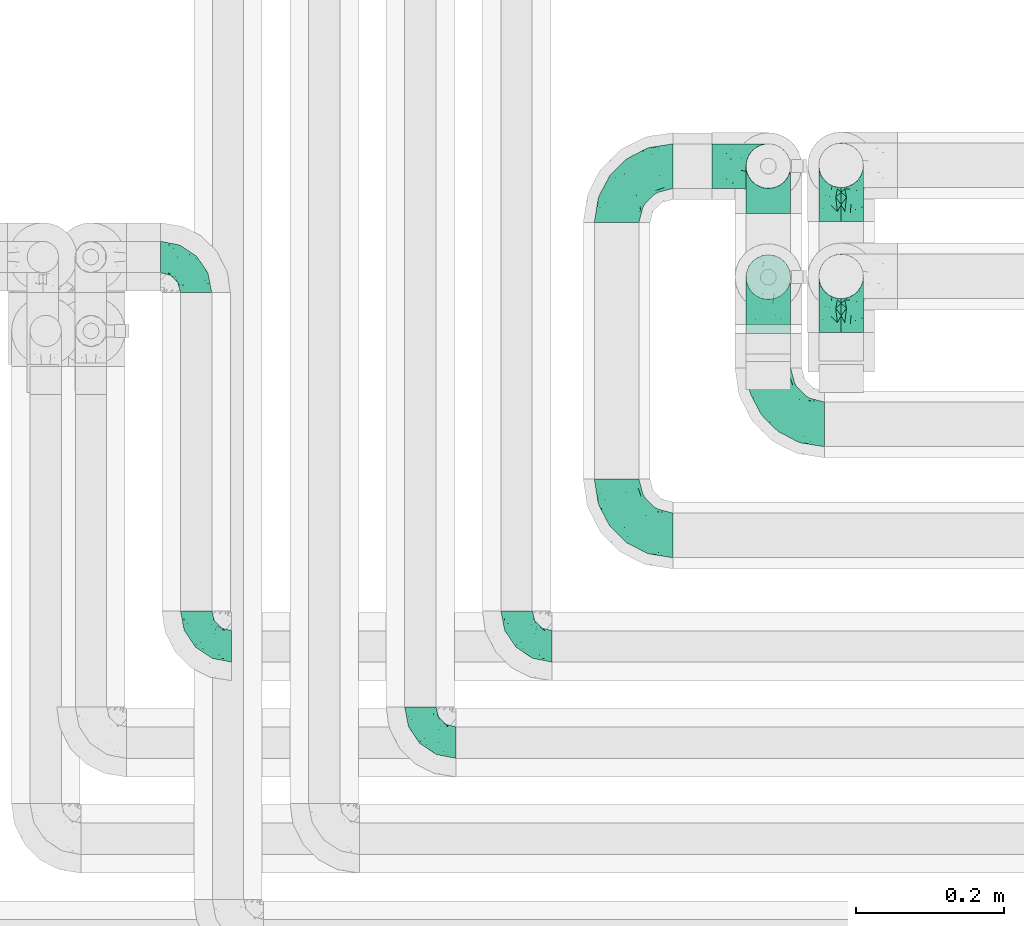
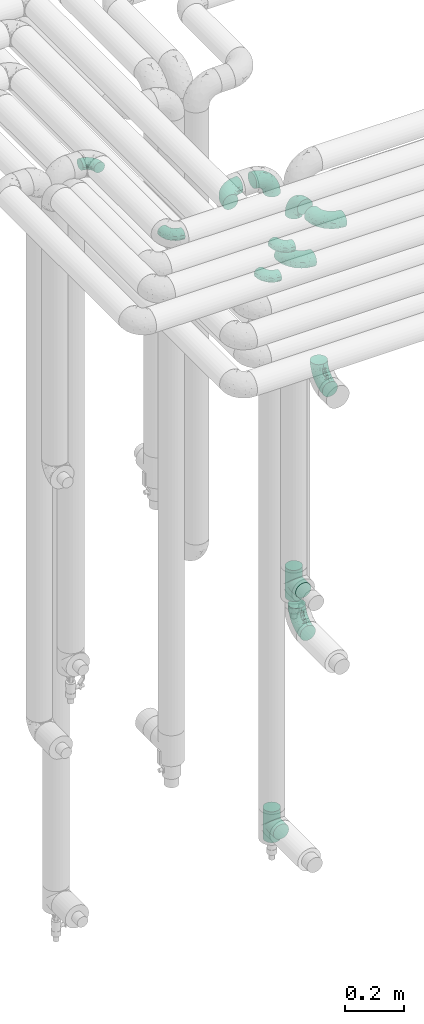
# One storey, part 631 of 827: 13 flow fittings.
"""IFC2X3 building model written with IfcOpenShell, lengths in millimetres."""

from ifc_helpers import new_model, entity, si_unit, converted_unit, derived_unit, direction, frame, origin, place, context, subcontext, project, spatial, faceted_brep, source, transform, mapped, material, type_object, type_shapes, element, save


model = new_model("IFC2X3")

# Units and contexts
model_context = context("Model", 3, precision=0.01, world=origin(), true_north=direction((6.12303176911189e-17, 1.0)))
body_context = subcontext(model_context, "Body", "Model", "MODEL_VIEW")
ifc_project = project(units=[si_unit("LENGTHUNIT", "METRE", prefix="MILLI"), si_unit("AREAUNIT", "SQUARE_METRE"), si_unit("VOLUMEUNIT", "CUBIC_METRE"), converted_unit("PLANEANGLEUNIT", "DEGREE", entity("IfcRatioMeasure", 0.0174532925199433), si_unit("PLANEANGLEUNIT", "RADIAN"), dimensions=[0, 0, 0, 0, 0, 0, 0]), si_unit("MASSUNIT", "GRAM", prefix="KILO"), derived_unit("MASSDENSITYUNIT", [(si_unit("MASSUNIT", "GRAM", prefix="KILO"), 1), (si_unit("LENGTHUNIT", "METRE"), -3)]), derived_unit("MOMENTOFINERTIAUNIT", [(si_unit("LENGTHUNIT", "METRE"), 4)]), si_unit("TIMEUNIT", "SECOND"), si_unit("FREQUENCYUNIT", "HERTZ"), si_unit("THERMODYNAMICTEMPERATUREUNIT", "DEGREE_CELSIUS"), derived_unit("THERMALTRANSMITTANCEUNIT", [(si_unit("MASSUNIT", "GRAM", prefix="KILO"), 1), (si_unit("THERMODYNAMICTEMPERATUREUNIT", "KELVIN"), -1), (si_unit("TIMEUNIT", "SECOND"), -3)]), derived_unit("VOLUMETRICFLOWRATEUNIT", [(si_unit("LENGTHUNIT", "METRE"), 3), (si_unit("TIMEUNIT", "SECOND"), -1)]), derived_unit("MASSFLOWRATEUNIT", [(si_unit("MASSUNIT", "GRAM", prefix="KILO"), 1), (si_unit("TIMEUNIT", "SECOND"), -1)]), derived_unit("ROTATIONALFREQUENCYUNIT", [(si_unit("TIMEUNIT", "SECOND"), -1)]), si_unit("ELECTRICCURRENTUNIT", "AMPERE"), si_unit("ELECTRICVOLTAGEUNIT", "VOLT"), si_unit("POWERUNIT", "WATT"), si_unit("FORCEUNIT", "NEWTON", prefix="KILO"), si_unit("ILLUMINANCEUNIT", "LUX"), si_unit("LUMINOUSFLUXUNIT", "LUMEN"), si_unit("LUMINOUSINTENSITYUNIT", "CANDELA"), derived_unit("USERDEFINED", [(si_unit("MASSUNIT", "GRAM", prefix="KILO"), -1), (si_unit("LENGTHUNIT", "METRE"), -2), (si_unit("TIMEUNIT", "SECOND"), 3), (si_unit("LUMINOUSFLUXUNIT", "LUMEN"), 1)]), derived_unit("LINEARVELOCITYUNIT", [(si_unit("LENGTHUNIT", "METRE"), 1), (si_unit("TIMEUNIT", "SECOND"), -1)]), si_unit("PRESSUREUNIT", "PASCAL"), derived_unit("USERDEFINED", [(si_unit("LENGTHUNIT", "METRE"), -2), (si_unit("MASSUNIT", "GRAM", prefix="KILO"), 1), (si_unit("TIMEUNIT", "SECOND"), -2)]), derived_unit("LINEARFORCEUNIT", [(si_unit("MASSUNIT", "GRAM", prefix="KILO"), 1), (si_unit("LENGTHUNIT", "METRE"), 1), (si_unit("TIMEUNIT", "SECOND"), -2), (si_unit("LENGTHUNIT", "METRE"), -1)]), derived_unit("PLANARFORCEUNIT", [(si_unit("MASSUNIT", "GRAM", prefix="KILO"), 1), (si_unit("LENGTHUNIT", "METRE"), 1), (si_unit("TIMEUNIT", "SECOND"), -2), (si_unit("LENGTHUNIT", "METRE"), -2)])], contexts=[model_context])

# Site, building, storey
site_placement = place(None, origin())
site = spatial("IfcSite", under=ifc_project, at=site_placement, CompositionType="ELEMENT")
building_placement = place(site_placement, origin())
building = spatial("IfcBuilding", under=site, at=building_placement, CompositionType="ELEMENT")
storey_placement = place(building_placement, frame((0.0, 0.0, 28200.0)))
storey = spatial("IfcBuildingStorey", under=building, at=storey_placement, Name="08", CompositionType="ELEMENT", Elevation=28200.0)

# Flow fittings
ifc_material = material()
pipe_fitting_type_1 = type_object("IfcPipeFittingType", Name="ADSK_1", PredefinedType="NOTDEFINED", material=ifc_material)
shared_shape_1 = source(origin(), body_context, "Body", "Brep", [
    faceted_brep([(-48.0, 10.6, -18.36), (-48.0, 5.49, -20.48), (-48.0, 0.0, -21.2), (-48.0, -5.49, -20.48), (-48.0, -10.6, -18.36), (-48.0, -14.99, -14.99), (-48.0, -18.36, -10.6), (-48.0, -20.48, -5.49), (-48.0, -21.2, 0.0), (-48.0, -20.48, 5.49), (-48.0, -18.36, 10.6), (-48.0, -14.99, 14.99), (-48.0, -10.6, 18.36), (-48.0, -5.49, 20.48), (-48.0, 0.0, 21.2), (-48.0, 5.49, 20.48), (-48.0, 10.6, 18.36), (-48.0, 14.99, 14.99), (-48.0, 18.36, 10.6), (-48.0, 20.48, 5.49), (-48.0, 21.2, 0.0), (-48.0, 20.48, -5.49), (-48.0, 18.36, -10.6), (-48.0, 14.99, -14.99), (0.0, 48.0, -21.2), (-5.49, 48.0, -20.48), (-10.6, 48.0, -18.36), (-14.99, 48.0, -14.99), (-18.36, 48.0, -10.6), (-20.48, 48.0, -5.49), (-21.2, 48.0, 0.0), (-20.48, 48.0, 5.49), (-18.36, 48.0, 10.6), (-14.99, 48.0, 14.99), (-10.6, 48.0, 18.36), (-5.49, 48.0, 20.48), (0.0, 48.0, 21.2), (5.49, 48.0, 20.48), (10.6, 48.0, 18.36), (14.99, 48.0, 14.99), (18.36, 48.0, 10.6), (20.48, 48.0, 5.49), (21.2, 48.0, 0.0), (20.48, 48.0, -5.49), (18.36, 48.0, -10.6), (14.99, 48.0, -14.99), (10.6, 48.0, -18.36), (5.49, 48.0, -20.48), (-35.25, -16.22, 12.01), (-34.76, -18.57, 0.0), (-20.87, -12.37, 10.9), (-31.49, -11.78, 15.9), (-37.0, -2.58, 20.86), (-33.89, 3.62, 21.15), (-31.81, -18.14, 6.76), (-5.78, 5.78, 17.67), (-19.42, -4.1, 17.86), (-9.6, -3.39, 13.73), (-35.44, -7.73, 19.13), (11.78, 31.49, 15.9), (-5.93, -5.46, 6.95), (-18.45, -13.78, 5.46), (-10.29, -8.43, 0.0), (-24.6, 0.55, 20.62), (-37.28, 17.94, 13.81), (-33.38, 22.85, 9.59), (-41.46, 20.06, 8.75), (-29.51, 20.45, 15.16), (-15.04, 10.79, 21.13), (-7.08, 16.98, 20.93), (-8.39, 23.51, 21.15), (-40.86, 13.03, 17.26), (-8.05, 41.26, 19.83), (-3.21, 35.97, 21.14), (8.53, 19.66, 14.74), (4.1, 19.42, 17.86), (-37.72, 22.66, 4.78), (-37.07, 8.58, 19.98), (-13.0, 5.43, 19.97), (-3.78, 13.93, 19.7), (3.02, 8.69, 13.43), (-2.27, -0.05, 10.65), (6.22, 6.99, 7.09), (-22.25, 34.6, 9.45), (18.14, 31.81, 6.76), (16.22, 35.25, 12.01), (12.37, 20.87, 10.9), (7.73, 35.44, 19.13), (-21.52, -15.93, 0.0), (2.58, 37.0, 20.86), (18.57, 34.76, 0.0), (13.78, 18.45, 5.46), (15.93, 21.52, 0.0), (-20.03, -8.54, 14.9), (-28.6, 28.6, 5.16), (-24.79, 34.6, 0.0), (-34.6, 24.79, 0.0), (-22.81, 37.41, 4.68), (-23.36, 26.33, 14.79), (-13.68, 37.05, 17.49), (-17.72, 38.12, 13.73), (-26.25, 27.3, 11.24), (-9.71, 32.34, 20.14), (-17.26, 25.6, 18.71), (-26.33, 9.99, 20.77), (-24.06, 6.05, 21.2), (-25.02, 15.46, 19.56), (-24.3, 20.72, 17.57), (-31.95, 15.23, 17.8), (-13.53, 24.7, 20.21), (-17.6, 17.6, 20.6), (-0.55, 24.6, 20.62), (-11.41, -7.48, 10.43), (0.93, -0.93, 0.0), (8.43, 10.29, 0.0), (-11.41, -7.48, -10.43), (-20.1, -8.84, -14.66), (-9.6, -3.39, -13.73), (7.73, 35.44, -19.13), (4.1, 19.42, -17.86), (-0.55, 24.6, -20.62), (-38.12, 17.72, -13.73), (-37.05, 13.68, -17.49), (-32.34, 9.71, -20.14), (-41.26, 8.05, -19.83), (-37.41, 22.81, -4.68), (-23.51, 8.39, -21.15), (-35.97, 3.21, -21.14), (-28.6, 28.6, -5.16), (-31.81, -18.14, -6.76), (-18.45, -13.78, -5.46), (-25.6, 17.26, -18.71), (-19.42, -4.1, -17.86), (-17.94, 37.28, -13.81), (-22.85, 33.38, -9.59), (-20.06, 41.46, -8.75), (-31.49, -11.78, -15.9), (-35.25, -16.22, -12.01), (8.53, 19.66, -14.74), (11.78, 31.49, -15.9), (-9.99, 26.33, -20.77), (-6.05, 24.06, -21.2), (-10.79, 15.04, -21.13), (-37.0, -2.58, -20.86), (-16.98, 7.08, -20.93), (-5.43, 13.0, -19.97), (-13.93, 3.78, -19.7), (-20.87, -12.37, -10.9), (-26.33, 23.36, -14.79), (-22.66, 37.72, -4.78), (13.78, 18.45, -5.46), (18.14, 31.81, -6.76), (-15.46, 25.02, -19.56), (-20.72, 24.3, -17.57), (16.22, 35.25, -12.01), (-13.03, 40.86, -17.26), (-8.58, 37.07, -19.98), (2.58, 37.0, -20.86), (-3.62, 33.89, -21.15), (-34.6, 22.25, -9.45), (6.22, 6.99, -7.09), (-20.45, 29.51, -15.16), (-35.44, -7.73, -19.13), (12.37, 20.87, -10.9), (-27.3, 26.25, -11.24), (-15.23, 31.95, -17.8), (-24.7, 13.53, -20.21), (-24.6, 0.55, -20.62), (-5.78, 5.78, -17.67), (-17.6, 17.6, -20.6), (3.02, 8.69, -13.43), (-5.93, -5.46, -6.95), (-2.27, -0.05, -10.65)], [[[0, 1, 2, 3, 4, 5, 6, 7, 8, 9, 10, 11, 12, 13, 14, 15, 16, 17, 18, 19, 20, 21, 22, 23]], [[24, 25, 26, 27, 28, 29, 30, 31, 32, 33, 34, 35, 36, 37, 38, 39, 40, 41, 42, 43, 44, 45, 46, 47]], [[10, 48, 11]], [[9, 8, 49]], [[48, 50, 51]], [[14, 52, 53]], [[10, 54, 48]], [[9, 54, 10]], [[55, 56, 57]], [[51, 12, 11]], [[51, 58, 12]], [[59, 39, 38]], [[60, 61, 62]], [[58, 56, 63]], [[64, 65, 66]], [[67, 65, 64]], [[68, 69, 70]], [[16, 71, 17]], [[13, 52, 14]], [[35, 72, 73]], [[14, 53, 15]], [[17, 64, 18]], [[74, 59, 75]], [[20, 19, 76]], [[66, 19, 18]], [[77, 15, 53]], [[15, 77, 16]], [[69, 78, 79]], [[80, 81, 82]], [[32, 31, 83]], [[84, 85, 86]], [[59, 87, 75]], [[61, 54, 88]], [[36, 89, 37]], [[84, 41, 40]], [[36, 35, 73]], [[90, 41, 84]], [[40, 39, 85]], [[12, 58, 13]], [[85, 84, 40]], [[91, 84, 86]], [[84, 92, 90]], [[87, 38, 37]], [[93, 56, 51]], [[65, 94, 76]], [[94, 95, 96]], [[84, 91, 92]], [[95, 97, 30]], [[98, 99, 100]], [[76, 94, 96]], [[101, 98, 83]], [[100, 99, 33]], [[102, 70, 73]], [[103, 102, 99]], [[94, 97, 95]], [[72, 99, 102]], [[72, 35, 34]], [[34, 33, 99]], [[9, 49, 54]], [[87, 59, 38]], [[104, 105, 68]], [[106, 103, 107]], [[106, 77, 104]], [[71, 64, 17]], [[108, 107, 67]], [[33, 32, 100]], [[109, 103, 110]], [[102, 109, 70]], [[89, 73, 111]], [[50, 48, 54]], [[51, 11, 48]], [[56, 58, 51]], [[88, 54, 49]], [[52, 58, 63]], [[50, 112, 93]], [[56, 55, 78]], [[39, 59, 85]], [[86, 85, 59]], [[89, 87, 37]], [[42, 41, 90]], [[111, 79, 75]], [[111, 75, 87]], [[75, 55, 80]], [[104, 77, 53]], [[71, 77, 108]], [[32, 83, 100]], [[98, 100, 83]], [[99, 98, 103]], [[106, 107, 108]], [[68, 70, 110]], [[111, 73, 70]], [[68, 110, 104]], [[68, 63, 78]], [[57, 93, 112]], [[80, 55, 57]], [[61, 50, 54]], [[80, 82, 86]], [[81, 57, 112]], [[74, 86, 59]], [[60, 113, 82]], [[82, 114, 91]], [[101, 94, 65]], [[97, 94, 83]], [[73, 89, 36]], [[87, 89, 111]], [[58, 52, 13]], [[53, 52, 63]], [[104, 53, 105]], [[106, 104, 110]], [[20, 76, 96]], [[76, 19, 66]], [[103, 106, 110]], [[77, 106, 108]], [[103, 98, 107]], [[67, 107, 98]], [[67, 98, 101]], [[108, 67, 64]], [[53, 63, 105]], [[63, 68, 105]], [[83, 31, 97]], [[30, 97, 31]], [[62, 113, 60]], [[112, 61, 60]], [[61, 88, 62]], [[86, 82, 91]], [[56, 78, 63]], [[114, 82, 113]], [[114, 92, 91]], [[79, 78, 55]], [[75, 79, 55]], [[69, 79, 111]], [[70, 69, 111]], [[78, 69, 68]], [[77, 71, 16]], [[64, 71, 108]], [[64, 66, 18]], [[76, 66, 65]], [[99, 72, 34]], [[73, 72, 102]], [[94, 101, 83]], [[67, 101, 65]], [[75, 80, 74]], [[80, 86, 74]], [[70, 109, 110]], [[102, 103, 109]], [[50, 93, 51]], [[57, 56, 93]], [[61, 112, 50]], [[81, 112, 60]], [[82, 81, 60]], [[80, 57, 81]], [[115, 116, 117]], [[118, 119, 120]], [[121, 122, 23]], [[123, 124, 122]], [[96, 125, 20]], [[123, 126, 127]], [[128, 96, 95]], [[129, 130, 88]], [[123, 122, 131]], [[116, 132, 117]], [[133, 134, 135]], [[0, 124, 1]], [[5, 136, 137]], [[138, 119, 139]], [[129, 88, 49]], [[140, 141, 142]], [[6, 5, 137]], [[46, 118, 47]], [[143, 3, 2]], [[144, 145, 146]], [[6, 129, 7]], [[129, 137, 147]], [[127, 2, 1]], [[148, 122, 121]], [[128, 125, 96]], [[134, 128, 149]], [[95, 149, 128]], [[150, 151, 92]], [[30, 29, 149]], [[152, 131, 153]], [[27, 133, 28]], [[154, 45, 44]], [[136, 5, 4]], [[27, 26, 155]], [[156, 26, 25]], [[24, 157, 158]], [[24, 47, 157]], [[22, 21, 159]], [[160, 150, 114]], [[134, 133, 161]], [[142, 144, 126]], [[46, 139, 118]], [[162, 136, 4]], [[156, 25, 158]], [[1, 124, 127]], [[115, 147, 116]], [[45, 154, 139]], [[139, 46, 45]], [[154, 163, 139]], [[162, 4, 3]], [[42, 90, 43]], [[130, 129, 147]], [[49, 7, 129]], [[43, 151, 44]], [[0, 23, 122]], [[24, 158, 25]], [[136, 162, 132]], [[135, 29, 28]], [[43, 90, 151]], [[164, 148, 159]], [[152, 156, 140]], [[155, 133, 27]], [[165, 153, 161]], [[23, 22, 121]], [[123, 131, 166]], [[123, 166, 126]], [[143, 127, 167]], [[147, 137, 136]], [[8, 7, 49]], [[129, 6, 137]], [[143, 162, 3]], [[167, 146, 132]], [[167, 132, 162]], [[132, 168, 117]], [[44, 151, 154]], [[92, 151, 90]], [[163, 154, 151]], [[119, 118, 139]], [[157, 118, 120]], [[138, 139, 163]], [[119, 168, 145]], [[140, 156, 158]], [[155, 156, 165]], [[22, 159, 121]], [[148, 121, 159]], [[122, 148, 131]], [[152, 153, 165]], [[142, 126, 169]], [[167, 127, 126]], [[142, 169, 140]], [[142, 120, 145]], [[168, 170, 117]], [[160, 171, 172]], [[115, 172, 171]], [[171, 62, 130]], [[119, 170, 168]], [[170, 163, 160]], [[150, 163, 151]], [[113, 171, 160]], [[164, 128, 134]], [[125, 128, 159]], [[127, 143, 2]], [[162, 143, 167]], [[118, 157, 47]], [[158, 157, 120]], [[140, 158, 141]], [[152, 140, 169]], [[30, 149, 95]], [[149, 29, 135]], [[131, 152, 169]], [[156, 152, 165]], [[131, 148, 153]], [[161, 153, 148]], [[161, 148, 164]], [[165, 161, 133]], [[158, 120, 141]], [[120, 142, 141]], [[159, 21, 125]], [[20, 125, 21]], [[115, 130, 147]], [[114, 113, 160]], [[62, 171, 113]], [[62, 88, 130]], [[160, 163, 150]], [[150, 92, 114]], [[119, 145, 120]], [[146, 145, 168]], [[132, 146, 168]], [[144, 146, 167]], [[126, 144, 167]], [[145, 144, 142]], [[156, 155, 26]], [[133, 155, 165]], [[133, 135, 28]], [[149, 135, 134]], [[122, 124, 0]], [[127, 124, 123]], [[128, 164, 159]], [[161, 164, 134]], [[163, 170, 138]], [[170, 119, 138]], [[131, 169, 166]], [[126, 166, 169]], [[147, 136, 116]], [[132, 116, 136]], [[172, 115, 117]], [[130, 115, 171]], [[117, 170, 172]], [[160, 172, 170]]]),
])
type_shapes(pipe_fitting_type_1, [shared_shape_1])
for number, where, z_axis, x_axis, name in (
    (1, (31176.52, 14360.0, 3200.0), (0.0, 0.0, 1.0), (0.0, -1.0, 0.0), "ADSK_1"),
    (2, (31306.52, 14490.0, 3200.0), (0.0, 0.0, 1.0), (0.0, -1.0, 0.0), "ADSK_1"),
    (3, (30873.54, 14490.0, 3400.0), (0.0, 0.0, 1.0), (0.0, -1.0, 0.0), "ADSK_1"),
    (4, (30873.54, 15016.2, 3400.0), (0.0, 0.0, 1.0), (0.0, 1.0, 0.0), "ADSK_1"),
):
    element("IfcFlowFitting", number, at=place(storey_placement, frame(where, z_axis=z_axis, x_axis=x_axis)), inside=storey, type_object=pipe_fitting_type_1, material=ifc_material, Name=name, ObjectType="ADSK_1", context=body_context, shape_type="MappedRepresentation", body=[
        mapped(shared_shape_1, transform((0.0, 0.0, 0.0), scale=1.0)),
    ])
pipe_fitting_type_2 = type_object("IfcPipeFittingType", Name="ADSK_1", PredefinedType="NOTDEFINED", material=ifc_material)
shared_shape_2 = source(origin(), body_context, "Body", "Brep", [
    faceted_brep([(-76.0, 15.07, -26.11), (-76.0, 7.8, -29.12), (-76.0, 0.0, -30.15), (-76.0, -7.8, -29.12), (-76.0, -15.08, -26.11), (-76.0, -21.32, -21.32), (-76.0, -26.11, -15.08), (-76.0, -29.12, -7.8), (-76.0, -30.15, 0.0), (-76.0, -29.12, 7.8), (-76.0, -26.11, 15.07), (-76.0, -21.32, 21.32), (-76.0, -15.08, 26.11), (-76.0, -7.8, 29.12), (-76.0, 0.0, 30.15), (-76.0, 7.8, 29.12), (-76.0, 15.07, 26.11), (-76.0, 21.32, 21.32), (-76.0, 26.11, 15.07), (-76.0, 29.12, 7.8), (-76.0, 30.15, 0.0), (-76.0, 29.12, -7.8), (-76.0, 26.11, -15.08), (-76.0, 21.32, -21.32), (0.0, 76.0, -30.15), (-7.8, 76.0, -29.12), (-15.07, 76.0, -26.11), (-21.32, 76.0, -21.32), (-26.11, 76.0, -15.08), (-29.12, 76.0, -7.8), (-30.15, 76.0, 0.0), (-29.12, 76.0, 7.8), (-26.11, 76.0, 15.07), (-21.32, 76.0, 21.32), (-15.07, 76.0, 26.11), (-7.8, 76.0, 29.12), (0.0, 76.0, 30.15), (7.8, 76.0, 29.12), (15.08, 76.0, 26.11), (21.32, 76.0, 21.32), (26.11, 76.0, 15.07), (29.12, 76.0, 7.8), (30.15, 76.0, 0.0), (29.12, 76.0, -7.8), (26.11, 76.0, -15.08), (21.32, 76.0, -21.32), (15.08, 76.0, -26.11), (7.8, 76.0, -29.12), (10.79, 31.43, 21.07), (4.32, 31.7, 25.72), (1.65, 15.19, 19.92), (-61.17, -27.8, 0.0), (-51.1, -25.49, 9.84), (-56.14, -10.61, 27.27), (-31.7, -4.32, 25.72), (-39.75, 1.72, 29.41), (-43.2, -24.95, 0.0), (-1.86, 1.86, 0.0), (4.49, 7.65, 5.78), (-7.82, -4.61, 5.83), (-56.21, -22.79, 17.21), (-58.98, -3.38, 29.7), (-53.96, 5.6, 30.07), (-10.86, 10.86, 25.48), (-17.2, -2.6, 20.44), (-49.15, -16.01, 22.7), (-22.18, -14.24, 7.99), (-28.4, -17.42, 0.0), (-13.61, -9.88, 0.0), (-39.0, 23.48, 27.76), (-58.76, 12.54, 28.36), (-41.61, 15.41, 29.48), (16.01, 49.15, 22.7), (-58.55, 25.93, 19.53), (-51.53, 33.5, 13.51), (-64.92, 28.76, 12.4), (-7.48, 23.14, 28.25), (-1.72, 39.75, 29.41), (-12.04, 27.88, 29.88), (-63.91, 18.81, 24.52), (-11.63, 65.16, 28.18), (-4.97, 57.02, 30.05), (9.88, 13.61, 0.0), (-62.5, 31.74, 5.02), (-45.17, 30.98, 21.2), (-21.78, 9.76, 28.58), (10.61, 56.14, 27.27), (-32.09, 54.42, 13.26), (22.79, 56.21, 17.21), (15.38, 31.17, 15.63), (25.49, 51.1, 9.84), (21.84, 36.35, 5.92), (24.95, 43.2, 0.0), (3.38, 58.98, 29.7), (-31.17, -15.38, 15.63), (-39.39, 41.78, 15.45), (-34.56, 41.13, 20.79), (-39.81, -23.25, 5.49), (27.8, 61.17, 0.0), (-31.74, 62.5, 5.02), (-53.07, 36.29, 0.0), (-42.95, 42.95, 7.29), (-36.29, 53.07, 0.0), (-19.83, 58.51, 24.79), (-25.48, 60.2, 19.41), (-14.53, 50.96, 28.57), (-13.31, 37.09, 30.07), (-26.16, 40.06, 26.4), (-32.43, -10.35, 21.9), (17.42, 28.4, 0.0), (14.24, 22.18, 7.99), (-38.67, 9.72, 30.15), (-24.66, 17.36, 30.09), (-37.08, 31.49, 24.99), (-49.27, 22.83, 25.24), (-20.8, 38.81, 28.63), (-27.58, 27.58, 29.2), (-36.07, -20.23, 10.71), (-15.19, -6.16, 14.9), (6.6, 15.4, 14.49), (-2.51, 2.51, 11.35), (-65.16, 11.63, -28.18), (-49.15, -16.01, -22.7), (-57.02, 4.97, -30.05), (-25.93, 58.55, -19.53), (-33.5, 51.53, -13.51), (-28.76, 64.92, -12.4), (-60.2, 25.48, -19.41), (-58.51, 19.83, -24.79), (4.61, 7.82, -5.83), (-7.65, -4.49, -5.78), (-2.51, 2.51, -11.35), (-62.5, 31.74, -5.02), (-50.96, 14.53, -28.57), (-37.09, 13.31, -30.07), (-42.95, 42.95, -7.29), (25.49, 51.1, -9.84), (22.79, 56.21, -17.21), (-40.06, 26.16, -26.4), (3.38, 58.98, -29.7), (-5.6, 53.96, -30.07), (-27.88, 12.04, -29.88), (-9.76, 21.78, -28.58), (-23.14, 7.48, -28.25), (-51.1, -25.49, -9.84), (15.38, 31.17, -15.63), (16.01, 49.15, -22.7), (-23.48, 39.0, -27.76), (-12.54, 58.76, -28.36), (-15.41, 41.61, -29.48), (-56.21, -22.79, -17.21), (-9.72, 38.67, -30.15), (-17.36, 24.66, -30.09), (-22.18, -14.24, -7.99), (-41.13, 34.56, -20.79), (-31.74, 62.5, -5.02), (-58.98, -3.38, -29.7), (-31.17, -15.38, -15.63), (-56.14, -10.61, -27.27), (14.24, 22.18, -7.99), (23.25, 39.81, -5.49), (-31.49, 37.08, -24.99), (-15.19, -6.16, -14.9), (1.65, 15.19, -19.92), (-18.81, 63.91, -24.52), (-32.59, -11.62, -20.84), (-31.7, -4.32, -25.72), (-17.2, -2.6, -20.44), (-39.75, 1.72, -29.41), (-54.42, 32.09, -13.26), (-30.98, 45.17, -21.2), (10.61, 56.14, -27.27), (10.23, 31.31, -21.52), (4.32, 31.7, -25.72), (-41.78, 39.39, -15.45), (-1.72, 39.75, -29.41), (-36.35, -21.84, -5.92), (-22.83, 49.27, -25.24), (-38.81, 20.8, -28.63), (-27.58, 27.58, -29.2), (-10.86, 10.86, -25.48), (20.23, 36.07, -10.71), (6.6, 15.4, -14.49)], [[[0, 1, 2, 3, 4, 5, 6, 7, 8, 9, 10, 11, 12, 13, 14, 15, 16, 17, 18, 19, 20, 21, 22, 23]], [[24, 25, 26, 27, 28, 29, 30, 31, 32, 33, 34, 35, 36, 37, 38, 39, 40, 41, 42, 43, 44, 45, 46, 47]], [[48, 49, 50]], [[51, 52, 9]], [[53, 54, 55]], [[9, 52, 10]], [[56, 52, 51]], [[57, 58, 59]], [[11, 10, 60]], [[14, 61, 62]], [[63, 54, 64]], [[65, 12, 11]], [[65, 53, 12]], [[66, 67, 68]], [[69, 70, 71]], [[72, 39, 38]], [[73, 74, 75]], [[15, 70, 16]], [[76, 77, 78]], [[16, 79, 17]], [[13, 61, 14]], [[35, 80, 81]], [[14, 62, 15]], [[17, 73, 18]], [[57, 82, 58]], [[20, 19, 83]], [[75, 19, 18]], [[70, 15, 62]], [[73, 84, 74]], [[78, 85, 76]], [[38, 86, 72]], [[32, 31, 87]], [[88, 89, 90]], [[91, 92, 90]], [[72, 86, 49]], [[36, 93, 37]], [[75, 83, 19]], [[36, 35, 81]], [[60, 94, 65]], [[40, 90, 41]], [[95, 96, 87]], [[88, 90, 40]], [[66, 97, 67]], [[90, 98, 41]], [[40, 39, 88]], [[99, 31, 30]], [[20, 83, 100]], [[101, 102, 100]], [[52, 60, 10]], [[102, 99, 30]], [[96, 103, 104]], [[83, 101, 100]], [[12, 53, 13]], [[104, 103, 33]], [[105, 106, 81]], [[107, 105, 103]], [[64, 54, 108]], [[80, 103, 105]], [[80, 35, 34]], [[34, 33, 103]], [[86, 38, 37]], [[109, 110, 82]], [[71, 111, 112]], [[69, 107, 113]], [[79, 73, 17]], [[114, 113, 84]], [[33, 32, 104]], [[115, 107, 116]], [[105, 115, 106]], [[93, 81, 77]], [[54, 53, 65]], [[61, 53, 55]], [[108, 94, 64]], [[54, 63, 85]], [[93, 86, 37]], [[77, 76, 49]], [[77, 49, 86]], [[49, 63, 50]], [[60, 52, 117]], [[65, 11, 60]], [[39, 72, 88]], [[89, 88, 72]], [[71, 70, 62]], [[79, 70, 114]], [[103, 96, 107]], [[69, 113, 114]], [[112, 106, 116]], [[77, 81, 106]], [[112, 116, 71]], [[112, 55, 85]], [[64, 50, 63]], [[57, 59, 68]], [[32, 87, 104]], [[96, 104, 87]], [[94, 118, 64]], [[50, 119, 89]], [[50, 64, 118]], [[50, 89, 48]], [[81, 93, 36]], [[86, 93, 77]], [[53, 61, 13]], [[62, 61, 55]], [[71, 62, 111]], [[69, 71, 116]], [[95, 101, 74]], [[99, 101, 87]], [[118, 66, 59]], [[117, 97, 66]], [[117, 66, 94]], [[91, 89, 110]], [[91, 110, 109]], [[110, 89, 119]], [[9, 8, 51]], [[98, 90, 92]], [[98, 42, 41]], [[101, 83, 74]], [[101, 99, 102]], [[87, 31, 99]], [[62, 55, 111]], [[55, 112, 111]], [[107, 69, 116]], [[70, 69, 114]], [[107, 96, 113]], [[84, 113, 96]], [[84, 96, 95]], [[114, 84, 73]], [[70, 79, 16]], [[73, 79, 114]], [[54, 85, 55]], [[76, 85, 63]], [[49, 76, 63]], [[77, 106, 78]], [[106, 112, 78]], [[85, 78, 112]], [[73, 75, 18]], [[83, 75, 74]], [[103, 80, 34]], [[81, 80, 105]], [[101, 95, 87]], [[84, 95, 74]], [[106, 115, 116]], [[105, 107, 115]], [[120, 59, 58]], [[82, 110, 58]], [[119, 58, 110]], [[118, 59, 120]], [[66, 68, 59]], [[54, 65, 108]], [[94, 108, 65]], [[66, 118, 94]], [[50, 118, 120]], [[50, 120, 119]], [[119, 120, 58]], [[89, 72, 48]], [[49, 48, 72]], [[60, 117, 94]], [[117, 52, 97]], [[52, 56, 97]], [[67, 97, 56]], [[92, 91, 109]], [[89, 91, 90]], [[121, 1, 0]], [[122, 5, 4]], [[2, 1, 123]], [[124, 125, 126]], [[127, 128, 23]], [[129, 130, 131]], [[100, 132, 20]], [[133, 134, 123]], [[135, 100, 102]], [[136, 137, 44]], [[133, 128, 138]], [[24, 139, 140]], [[141, 142, 143]], [[121, 128, 133]], [[6, 144, 7]], [[137, 145, 146]], [[144, 51, 7]], [[147, 148, 149]], [[144, 6, 150]], [[149, 151, 152]], [[153, 68, 67]], [[154, 128, 127]], [[30, 155, 102]], [[43, 42, 98]], [[156, 3, 2]], [[157, 144, 150]], [[158, 4, 3]], [[24, 140, 25]], [[155, 135, 102]], [[159, 160, 109]], [[30, 29, 155]], [[147, 138, 161]], [[27, 124, 28]], [[57, 129, 82]], [[162, 163, 131]], [[27, 26, 164]], [[148, 26, 25]], [[165, 166, 167]], [[24, 47, 139]], [[143, 168, 141]], [[22, 21, 169]], [[125, 124, 170]], [[148, 25, 140]], [[46, 146, 171]], [[158, 122, 4]], [[0, 23, 128]], [[1, 121, 123]], [[109, 82, 159]], [[45, 44, 137]], [[146, 46, 45]], [[136, 43, 98]], [[132, 21, 20]], [[136, 98, 92]], [[172, 173, 146]], [[46, 171, 47]], [[43, 136, 44]], [[174, 154, 169]], [[171, 173, 175]], [[6, 5, 150]], [[126, 29, 28]], [[176, 56, 144]], [[122, 158, 166]], [[164, 124, 27]], [[177, 161, 170]], [[23, 22, 127]], [[178, 138, 179]], [[133, 178, 134]], [[156, 123, 168]], [[156, 158, 3]], [[168, 143, 166]], [[168, 166, 158]], [[166, 180, 167]], [[173, 171, 146]], [[139, 171, 175]], [[172, 145, 163]], [[173, 180, 142]], [[5, 122, 150]], [[157, 150, 122]], [[137, 136, 181]], [[146, 45, 137]], [[149, 148, 140]], [[164, 148, 177]], [[128, 154, 138]], [[147, 161, 177]], [[152, 134, 179]], [[168, 123, 134]], [[152, 179, 149]], [[152, 175, 142]], [[57, 130, 129]], [[157, 165, 167]], [[22, 169, 127]], [[154, 127, 169]], [[163, 167, 180]], [[162, 157, 167]], [[173, 163, 180]], [[182, 163, 145]], [[123, 156, 2]], [[158, 156, 168]], [[171, 139, 47]], [[140, 139, 175]], [[149, 140, 151]], [[147, 149, 179]], [[174, 135, 125]], [[132, 135, 169]], [[176, 157, 153]], [[176, 153, 67]], [[153, 157, 162]], [[182, 159, 129]], [[181, 160, 159]], [[181, 159, 145]], [[51, 144, 56]], [[51, 8, 7]], [[135, 132, 100]], [[169, 21, 132]], [[126, 155, 29]], [[135, 155, 125]], [[140, 175, 151]], [[175, 152, 151]], [[138, 147, 179]], [[148, 147, 177]], [[138, 154, 161]], [[170, 161, 154]], [[170, 154, 174]], [[177, 170, 124]], [[148, 164, 26]], [[124, 164, 177]], [[173, 142, 175]], [[143, 142, 180]], [[166, 143, 180]], [[168, 134, 141]], [[134, 152, 141]], [[142, 141, 152]], [[124, 126, 28]], [[155, 126, 125]], [[128, 121, 0]], [[123, 121, 133]], [[135, 174, 169]], [[170, 174, 125]], [[134, 178, 179]], [[133, 138, 178]], [[130, 153, 162]], [[68, 153, 130]], [[57, 68, 130]], [[182, 129, 131]], [[159, 82, 129]], [[157, 122, 165]], [[166, 165, 122]], [[163, 162, 167]], [[162, 131, 130]], [[145, 172, 146]], [[163, 173, 172]], [[159, 182, 145]], [[131, 163, 182]], [[56, 176, 67]], [[157, 176, 144]], [[137, 181, 145]], [[181, 136, 160]], [[136, 92, 160]], [[109, 160, 92]]]),
])
type_shapes(pipe_fitting_type_2, [shared_shape_2])
for number, where, z_axis, x_axis, name in (
    (5, (31441.75, 14640.0, 3000.0), (0.0, 0.0, 1.0), (0.0, -1.0, 0.0), "ADSK_1"),
    (6, (31441.75, 15139.0, 3000.0), (0.0, 0.0, 1.0), (-1.0, 0.0, 0.0), "ADSK_1"),
    (7, (31745.03, 15140.0, 1110.0), (-1.0, 0.0, 0.0), (0.0, 0.0, -1.0), "ADSK_1"),
    (8, (31646.75, 15139.0, 3000.0), (0.0, 1.0, 0.0), (1.0, 0.0, 0.0), "ADSK_1"),
    (9, (31646.75, 14989.0, 3000.0), (1.0, 0.0, 0.0), (0.0, 0.0, 1.0), "ADSK_1"),
    (10, (31646.75, 14790.0, 3000.0), (0.0, 0.0, 1.0), (0.0, -1.0, 0.0), "ADSK_1"),
    (11, (31745.03, 14990.0, 2210.0), (-1.0, 0.0, 0.0), (0.0, 0.0, -1.0), "ADSK_1"),
):
    element("IfcFlowFitting", number, at=place(storey_placement, frame(where, z_axis=z_axis, x_axis=x_axis)), inside=storey, type_object=pipe_fitting_type_2, material=ifc_material, Name=name, ObjectType="ADSK_1", context=body_context, shape_type="MappedRepresentation", body=[
        mapped(shared_shape_2, transform((0.0, 0.0, 0.0), scale=1.0)),
    ])
pipe_fitting_type_3 = type_object("IfcPipeFittingType", Name="ADSK_1", PredefinedType="NOTDEFINED", material=ifc_material)
shared_shape_3 = source(origin(), body_context, "Body", "Brep", [
    faceted_brep([(-64.0, 15.07, -26.11), (-64.0, 7.8, -29.12), (-64.0, 0.0, -30.15), (-64.0, -7.8, -29.12), (-64.0, -15.08, -26.11), (-64.0, -21.32, -21.32), (-64.0, -26.11, -15.08), (-64.0, -29.12, -7.8), (-64.0, -30.15, 0.0), (-64.0, -29.12, 7.8), (-64.0, -26.11, 15.07), (-64.0, -21.32, 21.32), (-64.0, -15.08, 26.11), (-64.0, -7.8, 29.12), (-64.0, 0.0, 30.15), (-64.0, 7.8, 29.12), (-64.0, 15.07, 26.11), (-64.0, 21.32, 21.32), (-64.0, 26.11, 15.07), (-64.0, 29.12, 7.8), (-64.0, 30.15, 0.0), (-64.0, 29.12, -7.8), (-64.0, 26.11, -15.08), (-64.0, 21.32, -21.32), (64.0, 0.0, -30.15), (64.0, 7.8, -29.12), (64.0, 15.07, -26.11), (64.0, 21.32, -21.32), (64.0, 26.11, -15.08), (64.0, 29.12, -7.8), (64.0, 30.15, 0.0), (64.0, 29.12, 7.8), (64.0, 26.11, 15.07), (64.0, 21.32, 21.32), (64.0, 15.07, 26.11), (64.0, 7.8, 29.12), (64.0, 0.0, 30.15), (64.0, -7.8, 29.12), (64.0, -15.08, 26.11), (64.0, -21.32, 21.32), (64.0, -26.11, 15.07), (64.0, -29.12, 7.8), (64.0, -30.15, 0.0), (64.0, -29.12, -7.8), (64.0, -26.11, -15.08), (64.0, -21.32, -21.32), (64.0, -15.08, -26.11), (64.0, -7.8, -29.12), (29.06, -29.06, 8.05), (30.15, -30.15, 0.0), (-30.15, -30.15, 0.0), (26.09, -26.09, 15.1), (16.9, -16.9, 24.97), (21.88, -21.88, 20.75), (-29.06, -29.06, 8.05), (-26.09, -26.09, 15.1), (-21.88, -21.88, 20.75), (-16.9, -16.9, 24.97), (-11.47, -11.47, 27.88), (11.47, -11.47, 27.88), (5.79, -5.79, 29.59), (0.0, 0.0, 30.15), (-5.79, -5.79, 29.59), (5.79, -5.79, -29.59), (0.0, 0.0, -30.15), (-5.79, -5.79, -29.59), (-11.47, -11.47, -27.88), (11.47, -11.47, -27.88), (16.9, -16.9, -24.97), (21.88, -21.88, -20.75), (26.09, -26.09, -15.1), (29.06, -29.06, -8.05), (-16.9, -16.9, -24.97), (-21.88, -21.88, -20.75), (-29.06, -29.06, -8.05), (-26.09, -26.09, -15.1), (0.0, -64.0, -30.15), (7.8, -64.0, -29.12), (15.08, -64.0, -26.11), (21.32, -64.0, -21.32), (26.11, -64.0, -15.08), (29.12, -64.0, -7.8), (30.15, -64.0, 0.0), (29.12, -64.0, 7.8), (26.11, -64.0, 15.07), (21.32, -64.0, 21.32), (15.08, -64.0, 26.11), (7.8, -64.0, 29.12), (0.0, -64.0, 30.15), (-7.8, -64.0, 29.12), (-15.07, -64.0, 26.11), (-21.32, -64.0, 21.32), (-26.11, -64.0, 15.07), (-29.12, -64.0, 7.8), (-30.15, -64.0, 0.0), (-29.12, -64.0, -7.8), (-26.11, -64.0, -15.08), (-21.32, -64.0, -21.32), (-15.07, -64.0, -26.11), (-7.8, -64.0, -29.12)], [[[0, 1, 2, 3, 4, 5, 6, 7, 8, 9, 10, 11, 12, 13, 14, 15, 16, 17, 18, 19, 20, 21, 22, 23]], [[24, 25, 26, 27, 28, 29, 30, 31, 32, 33, 34, 35, 36, 37, 38, 39, 40, 41, 42, 43, 44, 45, 46, 47]], [[41, 40, 48]], [[42, 41, 49]], [[50, 9, 8]], [[49, 41, 48]], [[40, 51, 48]], [[39, 38, 52]], [[51, 40, 53]], [[52, 53, 39]], [[53, 40, 39]], [[50, 54, 9]], [[9, 54, 10]], [[54, 55, 10]], [[56, 57, 11]], [[11, 10, 56]], [[11, 57, 12]], [[56, 10, 55]], [[12, 57, 58]], [[52, 38, 59]], [[60, 36, 61]], [[62, 61, 14]], [[59, 37, 60]], [[37, 59, 38]], [[60, 37, 36]], [[61, 36, 35, 15, 14]], [[32, 31, 19, 18]], [[17, 16, 34, 33]], [[18, 17, 33, 32]], [[35, 34, 16, 15]], [[20, 19, 31, 30]], [[62, 13, 58]], [[13, 62, 14]], [[58, 13, 12]], [[27, 23, 22, 28]], [[22, 21, 29, 28]], [[0, 23, 27, 26]], [[20, 30, 29, 21]], [[24, 47, 63]], [[24, 64, 2, 1, 25]], [[64, 24, 63]], [[2, 64, 65]], [[26, 25, 1, 0]], [[65, 66, 3]], [[2, 65, 3]], [[66, 4, 3]], [[63, 47, 67]], [[46, 45, 68]], [[69, 68, 45]], [[44, 70, 69]], [[69, 45, 44]], [[46, 68, 67]], [[43, 42, 49]], [[7, 50, 8]], [[43, 71, 44]], [[71, 43, 49]], [[44, 71, 70]], [[72, 4, 66]], [[72, 5, 4]], [[5, 72, 73]], [[5, 73, 6]], [[74, 50, 7]], [[75, 74, 6]], [[74, 7, 6]], [[75, 6, 73]], [[46, 67, 47]], [[76, 77, 78, 79, 80, 81, 82, 83, 84, 85, 86, 87, 88, 89, 90, 91, 92, 93, 94, 95, 96, 97, 98, 99]], [[50, 94, 93]], [[54, 50, 93]], [[91, 90, 57]], [[56, 92, 91]], [[54, 93, 92]], [[58, 90, 89]], [[55, 54, 92]], [[56, 55, 92]], [[58, 57, 90]], [[88, 61, 62]], [[58, 89, 62]], [[56, 91, 57]], [[62, 89, 88]], [[60, 88, 87]], [[86, 59, 87]], [[84, 83, 48]], [[53, 85, 84]], [[52, 86, 85]], [[49, 83, 82]], [[59, 60, 87]], [[52, 59, 86]], [[49, 48, 83]], [[51, 53, 84]], [[48, 51, 84]], [[52, 85, 53]], [[88, 60, 61]], [[82, 81, 49]], [[71, 49, 81]], [[69, 80, 79]], [[79, 78, 68]], [[71, 81, 80]], [[67, 78, 77]], [[70, 71, 80]], [[69, 70, 80]], [[67, 68, 78]], [[76, 64, 63]], [[67, 77, 63]], [[69, 79, 68]], [[63, 77, 76]], [[65, 76, 99]], [[98, 66, 99]], [[96, 95, 74]], [[73, 97, 96]], [[72, 98, 97]], [[50, 95, 94]], [[66, 65, 99]], [[72, 66, 98]], [[50, 74, 95]], [[75, 73, 96]], [[74, 75, 96]], [[72, 97, 73]], [[76, 65, 64]]]),
])
type_shapes(pipe_fitting_type_3, [shared_shape_3])
for number, where, z_axis, x_axis, name in (
    (12, (31646.75, 15139.0, 315.5), (1.0, 0.0, 0.0), (0.0, 0.0, -1.0), "ADSK_1"),
    (13, (31646.75, 14989.0, 1405.5), (1.0, 0.0, 0.0), (0.0, 0.0, -1.0), "ADSK_1"),
):
    element("IfcFlowFitting", number, at=place(storey_placement, frame(where, z_axis=z_axis, x_axis=x_axis)), inside=storey, type_object=pipe_fitting_type_3, material=ifc_material, Name=name, ObjectType="ADSK_1", context=body_context, shape_type="MappedRepresentation", body=[
        mapped(shared_shape_3, transform((0.0, 0.0, 0.0), scale=1.0)),
    ])

save(model, "model.ifc")
